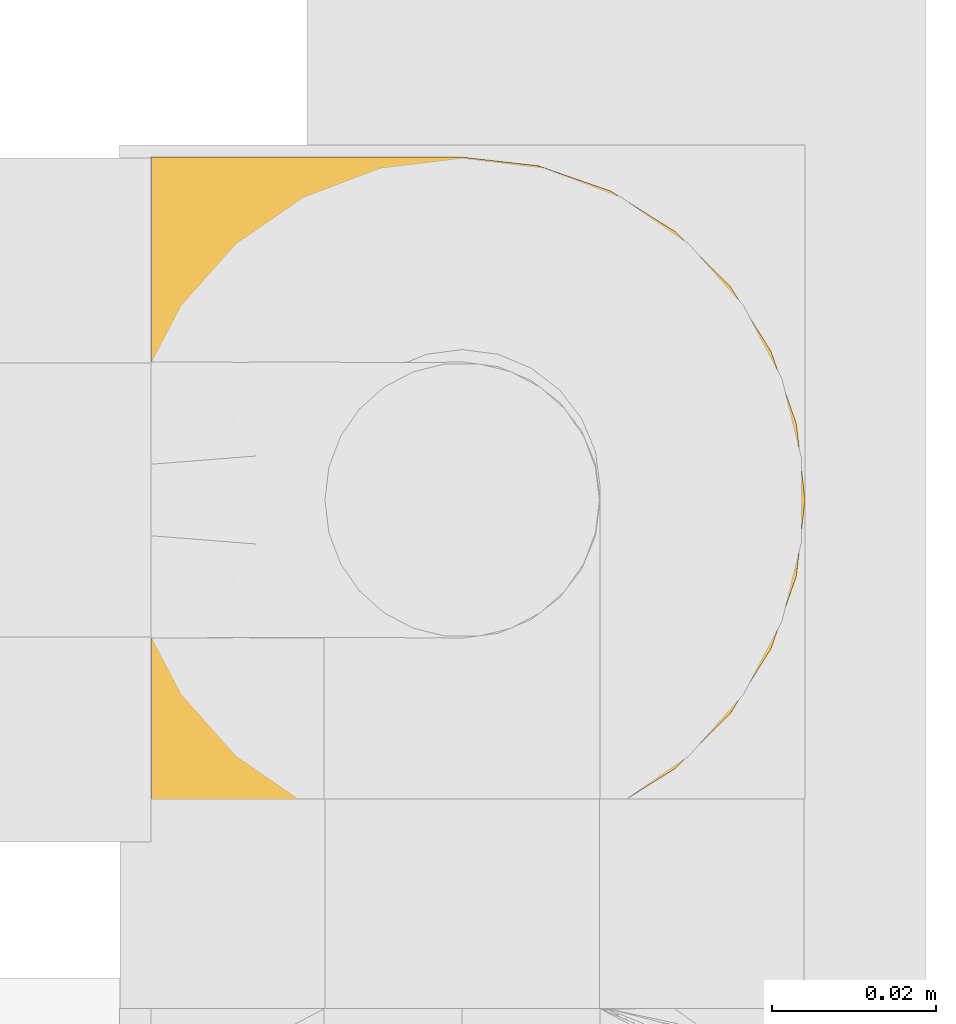
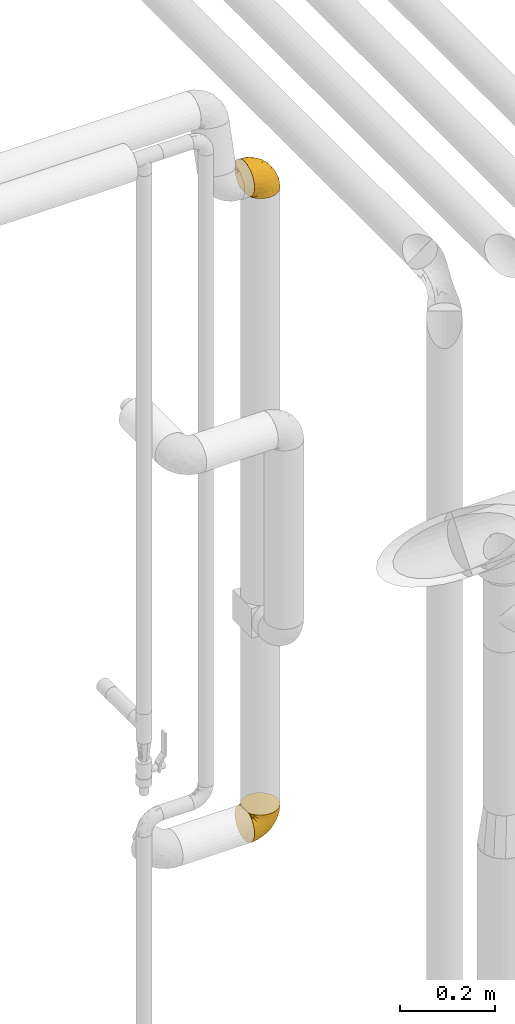
# One storey, part 355 of 827: 2 coverings.
"""IFC2X3 building model written with IfcOpenShell, lengths in millimetres."""

from ifc_helpers import new_model, entity, si_unit, converted_unit, derived_unit, direction, frame, origin, place, context, subcontext, project, spatial, faceted_brep, element, save


model = new_model("IFC2X3")

# Units and contexts
model_context = context("Model", 3, precision=0.01, world=origin(), true_north=direction((6.12303176911189e-17, 1.0)))
body_context = subcontext(model_context, "Body", "Model", "MODEL_VIEW")
ifc_project = project(units=[si_unit("LENGTHUNIT", "METRE", prefix="MILLI"), si_unit("AREAUNIT", "SQUARE_METRE"), si_unit("VOLUMEUNIT", "CUBIC_METRE"), converted_unit("PLANEANGLEUNIT", "DEGREE", entity("IfcRatioMeasure", 0.0174532925199433), si_unit("PLANEANGLEUNIT", "RADIAN"), dimensions=[0, 0, 0, 0, 0, 0, 0]), si_unit("MASSUNIT", "GRAM", prefix="KILO"), derived_unit("MASSDENSITYUNIT", [(si_unit("MASSUNIT", "GRAM", prefix="KILO"), 1), (si_unit("LENGTHUNIT", "METRE"), -3)]), derived_unit("MOMENTOFINERTIAUNIT", [(si_unit("LENGTHUNIT", "METRE"), 4)]), si_unit("TIMEUNIT", "SECOND"), si_unit("FREQUENCYUNIT", "HERTZ"), si_unit("THERMODYNAMICTEMPERATUREUNIT", "DEGREE_CELSIUS"), derived_unit("THERMALTRANSMITTANCEUNIT", [(si_unit("MASSUNIT", "GRAM", prefix="KILO"), 1), (si_unit("THERMODYNAMICTEMPERATUREUNIT", "KELVIN"), -1), (si_unit("TIMEUNIT", "SECOND"), -3)]), derived_unit("VOLUMETRICFLOWRATEUNIT", [(si_unit("LENGTHUNIT", "METRE"), 3), (si_unit("TIMEUNIT", "SECOND"), -1)]), derived_unit("MASSFLOWRATEUNIT", [(si_unit("MASSUNIT", "GRAM", prefix="KILO"), 1), (si_unit("TIMEUNIT", "SECOND"), -1)]), derived_unit("ROTATIONALFREQUENCYUNIT", [(si_unit("TIMEUNIT", "SECOND"), -1)]), si_unit("ELECTRICCURRENTUNIT", "AMPERE"), si_unit("ELECTRICVOLTAGEUNIT", "VOLT"), si_unit("POWERUNIT", "WATT"), si_unit("FORCEUNIT", "NEWTON", prefix="KILO"), si_unit("ILLUMINANCEUNIT", "LUX"), si_unit("LUMINOUSFLUXUNIT", "LUMEN"), si_unit("LUMINOUSINTENSITYUNIT", "CANDELA"), derived_unit("USERDEFINED", [(si_unit("MASSUNIT", "GRAM", prefix="KILO"), -1), (si_unit("LENGTHUNIT", "METRE"), -2), (si_unit("TIMEUNIT", "SECOND"), 3), (si_unit("LUMINOUSFLUXUNIT", "LUMEN"), 1)]), derived_unit("LINEARVELOCITYUNIT", [(si_unit("LENGTHUNIT", "METRE"), 1), (si_unit("TIMEUNIT", "SECOND"), -1)]), si_unit("PRESSUREUNIT", "PASCAL"), derived_unit("USERDEFINED", [(si_unit("LENGTHUNIT", "METRE"), -2), (si_unit("MASSUNIT", "GRAM", prefix="KILO"), 1), (si_unit("TIMEUNIT", "SECOND"), -2)]), derived_unit("LINEARFORCEUNIT", [(si_unit("MASSUNIT", "GRAM", prefix="KILO"), 1), (si_unit("LENGTHUNIT", "METRE"), 1), (si_unit("TIMEUNIT", "SECOND"), -2), (si_unit("LENGTHUNIT", "METRE"), -1)]), derived_unit("PLANARFORCEUNIT", [(si_unit("MASSUNIT", "GRAM", prefix="KILO"), 1), (si_unit("LENGTHUNIT", "METRE"), 1), (si_unit("TIMEUNIT", "SECOND"), -2), (si_unit("LENGTHUNIT", "METRE"), -2)])], contexts=[model_context])

# Site, building, storey
site_placement = place(None, origin())
site = spatial("IfcSite", under=ifc_project, at=site_placement, CompositionType="ELEMENT")
building_placement = place(site_placement, origin())
building = spatial("IfcBuilding", under=site, at=building_placement, CompositionType="ELEMENT")
storey_placement = place(building_placement, frame((0.0, 0.0, 28200.0)))
storey = spatial("IfcBuildingStorey", under=building, at=storey_placement, Name="08", CompositionType="ELEMENT", Elevation=28200.0)

# Coverings
covering_1_placement = place(storey_placement, frame((43536.62, 15237.88, 1117.26)))
element("IfcCovering", 1, at=covering_1_placement, inside=storey, Name=":ADSK_", ObjectType=":ADSK_", PredefinedType="INSULATION", context=body_context, shape_type="Brep", body=[
    faceted_brep([(57.76, 5.74, 81.45), (65.69, 10.73, 81.45), (72.32, 17.36, 81.45), (77.3, 25.29, 81.45), (80.4, 34.14, 81.45), (81.45, 43.45, 81.45), (80.39, 52.76, 81.45), (77.3, 61.61, 81.45), (72.31, 69.54, 81.45), (65.68, 76.17, 81.45), (57.75, 81.15, 81.45), (48.9, 84.25, 81.45), (39.6, 85.3, 81.45), (30.22, 84.23, 81.45), (21.33, 81.1, 81.45), (13.37, 76.06, 81.45), (6.73, 69.36, 81.45), (1.77, 61.36, 81.45), (1.77, 60.44, 81.45), (1.77, 59.52, 81.45), (1.77, 58.72, 81.45), (1.77, 57.4, 81.45), (1.77, 56.08, 81.45), (1.77, 54.76, 81.45), (1.77, 53.44, 81.45), (1.77, 52.12, 81.45), (1.77, 50.8, 81.45), (1.77, 49.47, 81.45), (1.77, 48.15, 81.45), (1.77, 46.83, 81.45), (1.77, 45.51, 81.45), (1.77, 44.19, 81.45), (1.77, 42.87, 81.45), (1.77, 41.55, 81.45), (1.77, 40.23, 81.45), (1.77, 39.31, 81.45), (1.77, 38.39, 81.45), (1.77, 37.48, 81.45), (1.77, 36.56, 81.45), (1.77, 35.64, 81.45), (1.77, 34.72, 81.45), (1.77, 33.8, 81.45), (1.77, 32.88, 81.45), (1.77, 31.96, 81.45), (1.77, 31.05, 81.45), (1.77, 30.13, 81.45), (1.77, 29.21, 81.45), (1.77, 28.29, 81.45), (1.77, 27.37, 81.45), (1.77, 26.45, 81.45), (1.77, 25.53, 81.45), (6.74, 17.52, 81.45), (13.38, 10.82, 81.45), (21.35, 5.78, 81.45), (30.24, 2.65, 81.45), (39.6, 1.6, 81.45), (48.91, 2.65, 81.45), (1.6, 69.37, 76.3), (1.6, 76.06, 69.67), (1.6, 81.1, 61.7), (1.6, 84.23, 52.81), (1.6, 85.3, 43.45), (1.6, 83.87, 32.61), (1.6, 79.69, 22.52), (1.6, 73.04, 13.85), (1.6, 64.37, 7.2), (1.6, 54.28, 3.02), (1.6, 43.45, 1.6), (1.6, 32.61, 3.02), (1.6, 22.52, 7.2), (1.6, 13.85, 13.85), (1.6, 7.2, 22.52), (1.6, 3.02, 32.61), (1.6, 1.6, 43.45), (1.6, 2.66, 52.81), (1.6, 5.79, 61.7), (1.6, 10.83, 69.67), (1.6, 17.52, 76.3), (1.6, 25.53, 81.27), (1.6, 26.45, 81.27), (1.6, 27.77, 81.27), (1.6, 28.89, 81.27), (1.6, 30.01, 81.27), (1.6, 31.13, 81.27), (1.6, 32.25, 81.27), (1.6, 33.37, 81.27), (1.6, 34.49, 81.27), (1.6, 35.61, 81.27), (1.6, 36.73, 81.27), (1.6, 37.85, 81.27), (1.6, 38.97, 81.27), (1.6, 40.09, 81.27), (1.6, 41.21, 81.27), (1.6, 42.33, 81.27), (1.6, 43.45, 81.27), (1.6, 44.77, 81.27), (1.6, 46.09, 81.27), (1.6, 47.41, 81.27), (1.6, 48.73, 81.27), (1.6, 50.05, 81.27), (1.6, 51.37, 81.27), (1.6, 52.69, 81.27), (1.6, 54.01, 81.27), (1.6, 54.93, 81.27), (1.6, 55.85, 81.27), (1.6, 56.76, 81.27), (1.6, 57.68, 81.27), (1.6, 58.6, 81.27), (1.6, 59.52, 81.27), (1.6, 60.44, 81.27), (1.6, 61.36, 81.27), (1.71, 32.81, 81.31), (1.73, 31.73, 81.33), (1.71, 50.71, 81.31), (1.72, 51.76, 81.32), (1.71, 42.89, 81.31), (1.72, 41.81, 81.32), (1.72, 25.53, 81.32), (1.72, 26.91, 81.32), (1.72, 40.71, 81.32), (1.72, 60.15, 81.32), (1.72, 39.53, 81.32), (1.72, 57.22, 81.32), (1.7, 58.17, 81.3), (1.72, 47.12, 81.32), (1.73, 33.93, 81.33), (1.72, 35.05, 81.31), (1.73, 46.09, 81.33), (1.73, 45.02, 81.32), (1.72, 43.95, 81.32), (1.72, 59.12, 81.32), (1.71, 38.49, 81.31), (1.72, 49.68, 81.32), (1.71, 53.35, 81.31), (1.72, 54.4, 81.32), (1.72, 56.2, 81.32), (1.72, 36.2, 81.32), (1.73, 37.29, 81.33), (1.72, 30.57, 81.32), (1.71, 29.45, 81.31), (1.73, 28.01, 81.33), (1.72, 61.36, 81.32), (1.74, 25.53, 81.36), (1.75, 25.53, 81.4), (1.75, 61.36, 81.4), (1.74, 61.36, 81.36), (1.64, 25.53, 81.29), (1.68, 25.53, 81.3), (1.68, 61.36, 81.3), (1.64, 61.36, 81.29), (1.74, 55.3, 81.35), (1.71, 48.18, 81.31), (8.98, 82.92, 58.5), (37.05, 85.3, 71.95), (24.69, 82.92, 74.57), (15.28, 78.8, 73.93), (16.86, 78.8, 78.18), (6.58, 70.46, 78.04), (5.71, 71.16, 76.23), (11.1, 85.3, 45.99), (10.79, 76.1, 74.01), (4.13, 72.9, 73.57), (6.62, 78.81, 66.66), (9.52, 72.89, 79.09), (6.14, 74.06, 73.14), (17.79, 83.71, 60.34), (20.6, 85.3, 48.54), (8.73, 85.3, 45.36), (23.66, 83.61, 67.22), (34.5, 85.3, 62.45), (15.32, 80.61, 68.67), (27.55, 85.3, 55.49), (3.31, 67.83, 77.84), (9.81, 78.81, 68.16), (37.68, 85.3, 74.31), (67.23, 54.78, 38.78), (76.64, 57.27, 62.1), (75.37, 43.45, 50.89), (14.58, 84.45, 36.91), (23.71, 84.39, 40.37), (34.34, 77.16, 27.86), (29.1, 68.92, 15.77), (18.02, 76.65, 20.13), (22.27, 82.11, 31.54), (10.97, 82.11, 28.25), (56.79, 78.88, 57.26), (60.76, 78.88, 69.99), (67.04, 73.04, 64.58), (36.11, 84.47, 50.64), (68.85, 65.72, 51.97), (24.58, 51.16, 5.72), (21.54, 59.46, 7.42), (78.4, 43.45, 66.14), (14.11, 68.92, 11.35), (53.42, 51.18, 21.64), (58.19, 57.42, 28.57), (44.49, 83.48, 55.38), (51.77, 82.95, 68.51), (73.69, 65.72, 67.48), (45.89, 78.97, 40.78), (35.97, 82.64, 41.53), (56.55, 75.14, 46.11), (60.03, 68.58, 40.32), (63.64, 61.95, 38.36), (34.98, 58.11, 11.84), (40.58, 51.07, 12.56), (32.15, 43.45, 7.67), (47.26, 58.51, 19.39), (58.06, 43.45, 24.98), (66.71, 43.45, 37.94), (16.9, 43.45, 4.64), (52.08, 65.68, 28.09), (41.21, 70.41, 23.73), (49.76, 73.04, 34.03), (45.11, 43.45, 16.33), (15.65, 4.78, 29.29), (24.57, 35.48, 5.77), (50.54, 29.45, 21.44), (67.25, 32.11, 38.8), (67.06, 13.86, 64.58), (73.7, 21.19, 67.49), (26.13, 10.24, 22.9), (19.54, 17.97, 12.54), (38.96, 18.88, 20.04), (56.8, 8.01, 57.26), (60.77, 8.01, 69.99), (51.78, 3.95, 68.51), (59.09, 22.45, 34.54), (19.25, 2.4, 38.81), (20.6, 1.6, 48.54), (11.1, 1.6, 45.99), (37.68, 1.6, 74.31), (15.21, 29.05, 5.36), (12.76, 10.24, 18.96), (40.93, 35.7, 12.79), (76.65, 29.63, 62.11), (39.5, 8.75, 33.14), (25.01, 4.54, 33.44), (68.86, 21.19, 51.98), (26.7, 2.28, 43.42), (34.95, 2.53, 48.62), (34.5, 1.6, 62.45), (27.55, 1.6, 55.49), (61.27, 13.86, 49.68), (44.5, 3.41, 55.37), (37.05, 1.6, 71.95), (10.25, 2.35, 36.37), (49.78, 13.86, 34.04), (47.51, 7.35, 44.1), (29.38, 27.43, 9.99), (40.01, 13.39, 26.41), (33.36, 4.32, 39.19), (8.98, 3.97, 58.5), (23.67, 3.27, 67.22), (24.71, 3.97, 74.57), (15.29, 8.08, 73.92), (4.13, 13.99, 73.57), (6.14, 12.83, 73.14), (4.96, 8.08, 66.19), (9.81, 8.08, 68.16), (3.31, 19.06, 77.84), (5.7, 15.74, 76.23), (9.53, 13.98, 79.08), (6.59, 16.42, 78.04), (16.63, 8.08, 77.18), (15.34, 6.27, 68.66), (10.8, 10.78, 74.0), (17.79, 3.18, 60.34)], [[[0, 1, 2, 3, 4, 5, 6, 7, 8, 9, 10, 11, 12, 13, 14, 15, 16, 17, 18, 19, 20, 21, 22, 23, 24, 25, 26, 27, 28, 29, 30, 31, 32, 33, 34, 35, 36, 37, 38, 39, 40, 41, 42, 43, 44, 45, 46, 47, 48, 49, 50, 51, 52, 53, 54, 55, 56]], [[57, 58, 59, 60, 61, 62, 63, 64, 65, 66, 67, 68, 69, 70, 71, 72, 73, 74, 75, 76, 77, 78, 79, 80, 81, 82, 83, 84, 85, 86, 87, 88, 89, 90, 91, 92, 93, 94, 95, 96, 97, 98, 99, 100, 101, 102, 103, 104, 105, 106, 107, 108, 109, 110]], [[111, 84, 112]], [[113, 26, 114]], [[114, 101, 100]], [[115, 93, 116]], [[79, 117, 118]], [[33, 116, 119]], [[117, 49, 118]], [[19, 18, 120]], [[119, 121, 34]], [[122, 21, 123]], [[97, 96, 124]], [[86, 125, 126]], [[116, 92, 119]], [[127, 96, 128]], [[32, 129, 115]], [[19, 120, 130]], [[121, 90, 131]], [[94, 115, 129]], [[115, 116, 32]], [[118, 49, 48]], [[113, 99, 132]], [[133, 114, 25]], [[24, 134, 133]], [[135, 22, 122]], [[136, 137, 88]], [[84, 83, 112]], [[138, 82, 139]], [[130, 20, 19]], [[118, 48, 140]], [[81, 140, 139]], [[123, 21, 20]], [[141, 120, 18]], [[139, 82, 81]], [[130, 107, 123]], [[49, 117, 142, 143, 50]], [[18, 17, 144, 145, 141]], [[79, 78, 146, 147, 117]], [[109, 141, 148, 149, 110]], [[102, 133, 134]], [[105, 135, 122]], [[118, 80, 79]], [[80, 118, 140]], [[120, 109, 108]], [[47, 46, 140, 48]], [[81, 80, 140]], [[44, 112, 138]], [[93, 115, 94]], [[46, 139, 140]], [[46, 45, 139]], [[139, 45, 138]], [[138, 112, 83]], [[85, 84, 111]], [[112, 43, 111]], [[83, 82, 138]], [[106, 122, 123]], [[105, 122, 106]], [[21, 122, 22]], [[124, 29, 28]], [[33, 32, 116]], [[128, 129, 31]], [[32, 31, 129]], [[34, 33, 119]], [[116, 93, 92]], [[129, 95, 94]], [[95, 129, 128]], [[41, 40, 125, 42]], [[119, 91, 121]], [[36, 35, 131, 37]], [[137, 131, 89]], [[121, 131, 35]], [[90, 121, 91]], [[119, 92, 91]], [[136, 126, 39]], [[125, 86, 85]], [[42, 125, 111]], [[85, 111, 125]], [[150, 23, 22]], [[130, 108, 107]], [[130, 123, 20]], [[107, 106, 123]], [[137, 37, 131]], [[136, 38, 137]], [[89, 88, 137]], [[131, 90, 89]], [[124, 151, 97]], [[40, 39, 126]], [[87, 126, 136]], [[86, 126, 87]], [[136, 88, 87]], [[40, 126, 125]], [[39, 38, 136]], [[95, 128, 96]], [[30, 128, 31]], [[29, 124, 127]], [[127, 128, 30]], [[151, 124, 28]], [[127, 30, 29]], [[127, 124, 96]], [[151, 98, 97]], [[45, 44, 138]], [[26, 113, 132]], [[113, 100, 99]], [[132, 151, 27]], [[27, 26, 132]], [[26, 25, 114]], [[100, 113, 114]], [[101, 133, 102]], [[133, 101, 114]], [[28, 27, 151]], [[132, 99, 98]], [[23, 134, 24]], [[25, 24, 133]], [[134, 23, 150]], [[135, 104, 150]], [[150, 104, 103]], [[103, 102, 134]], [[130, 120, 108]], [[109, 120, 141]], [[42, 111, 43]], [[112, 44, 43]], [[104, 135, 105]], [[134, 150, 103]], [[135, 150, 22]], [[35, 34, 121]], [[137, 38, 37]], [[98, 151, 132]], [[59, 152, 60]], [[13, 153, 154]], [[155, 156, 154]], [[157, 158, 141]], [[159, 60, 152]], [[160, 157, 155]], [[161, 162, 58]], [[58, 162, 59]], [[144, 16, 163]], [[58, 57, 161]], [[162, 161, 164]], [[157, 163, 155]], [[163, 16, 15]], [[57, 149, 161]], [[152, 165, 166]], [[157, 144, 163]], [[60, 159, 167, 61]], [[156, 14, 154]], [[163, 156, 155]], [[155, 154, 168]], [[168, 154, 169]], [[155, 170, 160]], [[57, 110, 149]], [[144, 17, 16]], [[156, 15, 14]], [[171, 165, 168]], [[158, 164, 172]], [[14, 13, 154]], [[157, 141, 145, 144]], [[173, 164, 158]], [[173, 160, 170]], [[171, 166, 165]], [[168, 165, 170]], [[168, 169, 171]], [[152, 173, 165]], [[170, 155, 168]], [[165, 173, 170]], [[160, 173, 158]], [[172, 149, 148]], [[148, 141, 158]], [[158, 157, 160]], [[152, 166, 159]], [[173, 152, 162]], [[59, 162, 152]], [[13, 12, 174, 153]], [[153, 169, 154]], [[15, 156, 163]], [[162, 164, 173]], [[172, 164, 161]], [[149, 172, 161]], [[158, 172, 148]], [[175, 176, 177]], [[178, 166, 179]], [[180, 181, 182]], [[183, 184, 178]], [[185, 186, 187]], [[171, 188, 179]], [[174, 12, 11]], [[189, 176, 175]], [[190, 66, 191]], [[176, 6, 192]], [[193, 65, 64]], [[63, 184, 182]], [[63, 182, 64]], [[65, 193, 191]], [[184, 63, 62]], [[175, 194, 195]], [[196, 169, 197]], [[174, 11, 197]], [[8, 7, 198]], [[187, 9, 8]], [[197, 169, 153, 174]], [[197, 11, 10]], [[186, 197, 10]], [[199, 180, 200]], [[197, 185, 196]], [[201, 189, 202]], [[201, 187, 189]], [[195, 203, 175]], [[191, 204, 190]], [[176, 7, 6]], [[177, 176, 192]], [[189, 198, 176]], [[65, 191, 66]], [[198, 187, 8]], [[205, 206, 190]], [[9, 186, 10]], [[181, 207, 204]], [[208, 175, 177, 209]], [[66, 190, 210]], [[211, 212, 213]], [[190, 204, 205]], [[180, 182, 183]], [[193, 182, 181]], [[62, 61, 167]], [[196, 185, 199]], [[196, 200, 188]], [[6, 5, 192]], [[176, 198, 7]], [[187, 198, 189]], [[187, 186, 9]], [[197, 186, 185]], [[200, 180, 183]], [[180, 213, 212]], [[179, 183, 178]], [[185, 201, 199]], [[210, 190, 206]], [[210, 67, 66]], [[205, 204, 207]], [[194, 205, 207]], [[194, 214, 205]], [[195, 194, 207]], [[208, 194, 175]], [[207, 211, 195]], [[202, 203, 211]], [[212, 207, 181]], [[202, 211, 213]], [[201, 202, 213]], [[189, 175, 203]], [[199, 201, 213]], [[187, 201, 185]], [[180, 199, 213]], [[196, 199, 200]], [[211, 203, 195]], [[189, 203, 202]], [[207, 212, 211]], [[180, 212, 181]], [[214, 194, 208]], [[214, 206, 205]], [[196, 188, 169]], [[181, 204, 191]], [[182, 193, 64]], [[191, 193, 181]], [[178, 62, 167]], [[182, 184, 183]], [[62, 178, 184]], [[178, 167, 159, 166]], [[171, 179, 166]], [[200, 183, 179]], [[179, 188, 200]], [[169, 188, 171]], [[71, 215, 72]], [[206, 216, 210]], [[217, 208, 218]], [[216, 68, 210]], [[219, 220, 2]], [[221, 222, 223]], [[224, 225, 226]], [[227, 223, 217]], [[228, 229, 230]], [[56, 231, 226]], [[232, 222, 69]], [[56, 55, 231]], [[70, 233, 71]], [[71, 233, 215]], [[0, 56, 226]], [[208, 217, 234]], [[218, 177, 235]], [[221, 236, 237]], [[238, 220, 219]], [[1, 219, 2]], [[68, 216, 232]], [[235, 3, 220]], [[235, 192, 4]], [[1, 0, 225]], [[228, 239, 229]], [[240, 241, 242]], [[243, 238, 219]], [[224, 226, 244]], [[226, 241, 244]], [[3, 235, 4]], [[69, 222, 70]], [[225, 219, 1]], [[218, 235, 238]], [[243, 219, 224]], [[218, 227, 217]], [[3, 2, 220]], [[218, 208, 209, 177]], [[226, 231, 245, 241]], [[215, 228, 246]], [[247, 248, 236]], [[248, 224, 244]], [[223, 222, 249]], [[233, 222, 221]], [[242, 239, 240]], [[248, 247, 243]], [[217, 223, 249]], [[250, 247, 236]], [[216, 234, 249]], [[218, 238, 227]], [[192, 235, 177]], [[192, 5, 4]], [[72, 246, 73]], [[235, 220, 238]], [[226, 225, 0]], [[219, 225, 224]], [[240, 248, 244]], [[239, 242, 229]], [[236, 248, 251]], [[68, 67, 210]], [[234, 216, 206]], [[216, 249, 232]], [[234, 206, 214, 208]], [[249, 234, 217]], [[222, 232, 249]], [[69, 68, 232]], [[246, 228, 230]], [[237, 228, 215]], [[243, 227, 238]], [[223, 227, 247]], [[73, 246, 230]], [[215, 246, 72]], [[248, 243, 224]], [[227, 243, 247]], [[237, 236, 251]], [[250, 221, 223]], [[222, 233, 70]], [[215, 233, 221]], [[221, 237, 215]], [[239, 237, 251]], [[237, 239, 228]], [[239, 251, 240]], [[248, 240, 251]], [[241, 240, 244]], [[221, 250, 236]], [[223, 247, 250]], [[74, 230, 252]], [[253, 254, 255]], [[146, 77, 256]], [[257, 258, 259]], [[260, 256, 257]], [[260, 261, 147]], [[75, 74, 252]], [[51, 143, 262]], [[263, 143, 142, 117]], [[256, 77, 76]], [[252, 258, 75]], [[253, 241, 254]], [[254, 245, 54]], [[258, 256, 76]], [[53, 52, 264]], [[255, 265, 253]], [[254, 264, 255]], [[255, 264, 262]], [[75, 258, 76]], [[265, 255, 266]], [[255, 262, 263]], [[51, 50, 143]], [[54, 245, 231, 55]], [[51, 262, 52]], [[253, 267, 242]], [[254, 54, 53]], [[266, 259, 265]], [[146, 78, 77]], [[263, 117, 261]], [[146, 256, 260]], [[257, 259, 261]], [[267, 253, 265]], [[229, 267, 252]], [[242, 267, 229]], [[242, 241, 253]], [[252, 267, 259]], [[255, 263, 266]], [[259, 267, 265]], [[261, 117, 147]], [[263, 261, 266]], [[259, 266, 261]], [[230, 74, 73]], [[230, 229, 252]], [[259, 258, 252]], [[254, 241, 245]], [[53, 264, 254]], [[52, 262, 264]], [[143, 263, 262]], [[258, 257, 256]], [[261, 260, 257]], [[146, 260, 147]]]),
])
covering_2_placement = place(storey_placement, frame((43536.62, 15237.88, 2782.61)))
element("IfcCovering", 2, at=covering_2_placement, inside=storey, Name=":ADSK_", ObjectType=":ADSK_", PredefinedType="INSULATION", context=body_context, shape_type="Brep", body=[
    faceted_brep([(57.76, 81.15, 1.6), (65.69, 76.16, 1.6), (72.32, 69.53, 1.6), (77.3, 61.6, 1.6), (80.4, 52.75, 1.6), (81.45, 43.45, 1.6), (80.39, 34.13, 1.6), (77.3, 25.28, 1.6), (72.31, 17.35, 1.6), (65.68, 10.72, 1.6), (57.75, 5.74, 1.6), (48.9, 2.64, 1.6), (39.6, 1.6, 1.6), (30.22, 2.66, 1.6), (21.33, 5.79, 1.6), (13.37, 10.83, 1.6), (6.73, 17.53, 1.6), (1.77, 25.53, 1.6), (1.77, 26.45, 1.6), (1.77, 27.37, 1.6), (1.77, 28.17, 1.6), (1.77, 29.49, 1.6), (1.77, 30.81, 1.6), (1.77, 32.13, 1.6), (1.77, 33.45, 1.6), (1.77, 34.78, 1.6), (1.77, 36.1, 1.6), (1.77, 37.42, 1.6), (1.77, 38.74, 1.6), (1.77, 40.06, 1.6), (1.77, 41.38, 1.6), (1.77, 42.7, 1.6), (1.77, 44.02, 1.6), (1.77, 45.34, 1.6), (1.77, 46.66, 1.6), (1.77, 47.58, 1.6), (1.77, 48.5, 1.6), (1.77, 49.41, 1.6), (1.77, 50.33, 1.6), (1.77, 51.25, 1.6), (1.77, 52.17, 1.6), (1.77, 53.09, 1.6), (1.77, 54.01, 1.6), (1.77, 54.93, 1.6), (1.77, 55.85, 1.6), (1.77, 56.76, 1.6), (1.77, 57.68, 1.6), (1.77, 58.6, 1.6), (1.77, 59.52, 1.6), (1.77, 60.44, 1.6), (1.77, 61.36, 1.6), (6.74, 69.37, 1.6), (13.38, 76.07, 1.6), (21.35, 81.11, 1.6), (30.24, 84.24, 1.6), (39.6, 85.3, 1.6), (48.91, 84.24, 1.6), (1.6, 17.52, 6.74), (1.6, 10.83, 13.37), (1.6, 5.79, 21.34), (1.6, 2.66, 30.23), (1.6, 1.6, 39.6), (1.6, 3.02, 50.43), (1.6, 7.2, 60.52), (1.6, 13.85, 69.19), (1.6, 22.52, 75.84), (1.6, 32.61, 80.02), (1.6, 43.45, 81.45), (1.6, 54.28, 80.02), (1.6, 64.37, 75.84), (1.6, 73.04, 69.19), (1.6, 79.69, 60.52), (1.6, 83.87, 50.43), (1.6, 85.3, 39.6), (1.6, 84.23, 30.23), (1.6, 81.1, 21.34), (1.6, 76.06, 13.37), (1.6, 69.37, 6.74), (1.6, 61.36, 1.77), (1.6, 60.44, 1.77), (1.6, 59.12, 1.77), (1.6, 58.0, 1.77), (1.6, 56.88, 1.77), (1.6, 55.76, 1.77), (1.6, 54.64, 1.77), (1.6, 53.52, 1.77), (1.6, 52.4, 1.77), (1.6, 51.28, 1.77), (1.6, 50.16, 1.77), (1.6, 49.04, 1.77), (1.6, 47.92, 1.77), (1.6, 46.8, 1.77), (1.6, 45.68, 1.77), (1.6, 44.56, 1.77), (1.6, 43.45, 1.77), (1.6, 42.12, 1.77), (1.6, 40.8, 1.77), (1.6, 39.48, 1.77), (1.6, 38.16, 1.77), (1.6, 36.84, 1.77), (1.6, 35.52, 1.77), (1.6, 34.2, 1.77), (1.6, 32.88, 1.77), (1.6, 31.96, 1.77), (1.6, 31.05, 1.77), (1.6, 30.13, 1.77), (1.6, 29.21, 1.77), (1.6, 28.29, 1.77), (1.6, 27.37, 1.77), (1.6, 26.45, 1.77), (1.6, 25.53, 1.77), (1.71, 54.08, 1.73), (1.73, 55.16, 1.72), (1.71, 36.18, 1.73), (1.72, 35.13, 1.72), (1.71, 44.01, 1.73), (1.72, 45.08, 1.73), (1.72, 61.36, 1.72), (1.72, 59.98, 1.72), (1.72, 46.18, 1.72), (1.72, 26.74, 1.72), (1.72, 47.36, 1.72), (1.72, 29.67, 1.73), (1.7, 28.72, 1.74), (1.72, 39.77, 1.72), (1.73, 52.96, 1.71), (1.72, 51.84, 1.73), (1.73, 40.8, 1.71), (1.73, 41.87, 1.72), (1.72, 42.94, 1.73), (1.72, 27.77, 1.72), (1.71, 48.4, 1.73), (1.72, 37.21, 1.72), (1.71, 33.54, 1.73), (1.72, 32.49, 1.72), (1.72, 30.69, 1.72), (1.72, 50.69, 1.72), (1.73, 49.6, 1.71), (1.72, 56.32, 1.72), (1.71, 57.44, 1.73), (1.73, 58.88, 1.71), (1.72, 25.53, 1.72), (1.74, 61.36, 1.68), (1.75, 61.36, 1.64), (1.75, 25.53, 1.64), (1.74, 25.53, 1.68), (1.64, 61.36, 1.75), (1.68, 61.36, 1.74), (1.68, 25.53, 1.74), (1.64, 25.53, 1.75), (1.74, 31.59, 1.7), (1.71, 38.71, 1.73), (8.98, 3.97, 24.54), (37.05, 1.6, 11.1), (24.69, 3.97, 8.47), (15.28, 8.09, 9.11), (16.86, 8.09, 4.86), (6.58, 16.43, 5.0), (5.71, 15.73, 6.81), (11.1, 1.6, 37.05), (10.79, 10.79, 9.03), (4.13, 13.99, 9.47), (6.62, 8.08, 16.39), (9.52, 14.0, 3.95), (6.14, 12.83, 9.9), (17.79, 3.18, 22.7), (20.6, 1.6, 34.5), (8.73, 1.6, 37.68), (23.66, 3.28, 15.82), (34.5, 1.6, 20.6), (15.32, 6.28, 14.37), (27.55, 1.6, 27.55), (3.31, 19.06, 5.2), (9.81, 8.08, 14.88), (37.68, 1.6, 8.73), (67.23, 32.11, 44.27), (76.64, 29.62, 20.94), (75.37, 43.45, 32.15), (14.58, 2.45, 46.13), (23.71, 2.5, 42.67), (34.34, 9.73, 55.18), (29.1, 17.97, 67.27), (18.02, 10.24, 62.91), (22.27, 4.78, 51.5), (10.97, 4.78, 54.79), (56.79, 8.01, 25.78), (60.76, 8.01, 13.05), (67.04, 13.85, 18.46), (36.11, 2.42, 32.4), (68.85, 21.17, 31.07), (24.58, 35.73, 77.32), (21.54, 27.43, 75.62), (78.4, 43.45, 16.9), (14.11, 17.97, 71.69), (53.42, 35.71, 61.4), (58.19, 29.47, 54.47), (44.49, 3.41, 27.66), (51.77, 3.94, 14.53), (73.69, 21.17, 15.56), (45.89, 7.92, 42.26), (35.97, 4.25, 41.51), (56.55, 11.75, 36.93), (60.03, 18.31, 42.72), (63.64, 24.94, 44.68), (34.98, 28.78, 71.2), (40.58, 35.82, 70.48), (32.15, 43.45, 75.37), (47.26, 28.38, 63.65), (58.06, 43.45, 58.06), (66.71, 43.45, 45.11), (16.9, 43.45, 78.4), (52.08, 21.21, 54.95), (41.21, 16.48, 59.31), (49.76, 13.85, 49.01), (45.11, 43.45, 66.71), (15.65, 82.11, 53.75), (24.57, 51.41, 77.27), (50.54, 57.45, 61.6), (67.25, 54.78, 44.24), (67.06, 73.03, 18.46), (73.7, 65.7, 15.55), (26.13, 76.65, 60.14), (19.54, 68.92, 70.5), (38.96, 68.01, 63.0), (56.8, 78.88, 25.78), (60.77, 78.88, 13.05), (51.78, 82.94, 14.53), (59.09, 64.44, 48.5), (19.25, 84.49, 44.23), (20.6, 85.3, 34.5), (11.1, 85.3, 37.05), (37.68, 85.3, 8.73), (15.21, 57.84, 77.68), (12.76, 76.65, 64.08), (40.93, 51.19, 70.25), (76.65, 57.26, 20.93), (39.5, 78.14, 49.9), (25.01, 82.35, 49.6), (68.86, 65.7, 31.06), (26.7, 84.61, 39.62), (34.95, 84.36, 34.42), (34.5, 85.3, 20.6), (27.55, 85.3, 27.55), (61.27, 73.03, 33.36), (44.5, 83.48, 27.68), (37.05, 85.3, 11.1), (10.25, 84.54, 46.67), (49.78, 73.03, 49.0), (47.51, 79.54, 38.94), (29.38, 59.46, 73.05), (40.01, 73.5, 56.63), (33.36, 82.57, 43.85), (8.98, 82.92, 24.54), (23.67, 83.62, 15.82), (24.71, 82.92, 8.47), (15.29, 78.81, 9.12), (4.13, 72.9, 9.47), (6.14, 74.06, 9.91), (4.96, 78.81, 16.85), (9.81, 78.81, 14.88), (3.31, 67.83, 5.2), (5.7, 71.15, 6.81), (9.53, 72.91, 3.96), (6.59, 70.47, 5.0), (16.63, 78.81, 5.86), (15.34, 80.62, 14.38), (10.8, 76.11, 9.04), (17.79, 83.71, 22.7)], [[[0, 1, 2, 3, 4, 5, 6, 7, 8, 9, 10, 11, 12, 13, 14, 15, 16, 17, 18, 19, 20, 21, 22, 23, 24, 25, 26, 27, 28, 29, 30, 31, 32, 33, 34, 35, 36, 37, 38, 39, 40, 41, 42, 43, 44, 45, 46, 47, 48, 49, 50, 51, 52, 53, 54, 55, 56]], [[57, 58, 59, 60, 61, 62, 63, 64, 65, 66, 67, 68, 69, 70, 71, 72, 73, 74, 75, 76, 77, 78, 79, 80, 81, 82, 83, 84, 85, 86, 87, 88, 89, 90, 91, 92, 93, 94, 95, 96, 97, 98, 99, 100, 101, 102, 103, 104, 105, 106, 107, 108, 109, 110]], [[111, 84, 112]], [[113, 26, 114]], [[114, 101, 100]], [[115, 93, 116]], [[79, 117, 118]], [[33, 116, 119]], [[117, 49, 118]], [[19, 18, 120]], [[119, 121, 34]], [[122, 21, 123]], [[97, 96, 124]], [[86, 125, 126]], [[116, 92, 119]], [[127, 96, 128]], [[32, 129, 115]], [[19, 120, 130]], [[121, 90, 131]], [[94, 115, 129]], [[115, 116, 32]], [[118, 49, 48]], [[113, 99, 132]], [[133, 114, 25]], [[24, 134, 133]], [[135, 22, 122]], [[136, 137, 88]], [[84, 83, 112]], [[138, 82, 139]], [[130, 20, 19]], [[118, 48, 140]], [[81, 140, 139]], [[123, 21, 20]], [[141, 120, 18]], [[139, 82, 81]], [[130, 107, 123]], [[49, 117, 142, 143, 50]], [[18, 17, 144, 145, 141]], [[79, 78, 146, 147, 117]], [[109, 141, 148, 149, 110]], [[102, 133, 134]], [[105, 135, 122]], [[118, 80, 79]], [[80, 118, 140]], [[120, 109, 108]], [[47, 46, 140, 48]], [[81, 80, 140]], [[44, 112, 138]], [[93, 115, 94]], [[46, 139, 140]], [[46, 45, 139]], [[139, 45, 138]], [[138, 112, 83]], [[85, 84, 111]], [[112, 43, 111]], [[83, 82, 138]], [[106, 122, 123]], [[105, 122, 106]], [[21, 122, 22]], [[124, 29, 28]], [[33, 32, 116]], [[128, 129, 31]], [[32, 31, 129]], [[34, 33, 119]], [[116, 93, 92]], [[129, 95, 94]], [[95, 129, 128]], [[41, 40, 125, 42]], [[119, 91, 121]], [[36, 35, 131, 37]], [[137, 131, 89]], [[121, 131, 35]], [[90, 121, 91]], [[119, 92, 91]], [[136, 126, 39]], [[125, 86, 85]], [[42, 125, 111]], [[85, 111, 125]], [[150, 23, 22]], [[130, 108, 107]], [[130, 123, 20]], [[107, 106, 123]], [[137, 37, 131]], [[136, 38, 137]], [[89, 88, 137]], [[131, 90, 89]], [[124, 151, 97]], [[40, 39, 126]], [[87, 126, 136]], [[86, 126, 87]], [[136, 88, 87]], [[40, 126, 125]], [[39, 38, 136]], [[95, 128, 96]], [[30, 128, 31]], [[29, 124, 127]], [[127, 128, 30]], [[151, 124, 28]], [[127, 30, 29]], [[127, 124, 96]], [[151, 98, 97]], [[45, 44, 138]], [[26, 113, 132]], [[113, 100, 99]], [[132, 151, 27]], [[27, 26, 132]], [[26, 25, 114]], [[100, 113, 114]], [[101, 133, 102]], [[133, 101, 114]], [[28, 27, 151]], [[132, 99, 98]], [[23, 134, 24]], [[25, 24, 133]], [[134, 23, 150]], [[135, 104, 150]], [[150, 104, 103]], [[103, 102, 134]], [[130, 120, 108]], [[109, 120, 141]], [[42, 111, 43]], [[112, 44, 43]], [[104, 135, 105]], [[134, 150, 103]], [[135, 150, 22]], [[35, 34, 121]], [[137, 38, 37]], [[98, 151, 132]], [[59, 152, 60]], [[13, 153, 154]], [[155, 156, 154]], [[157, 158, 141]], [[159, 60, 152]], [[160, 157, 155]], [[161, 162, 58]], [[58, 162, 59]], [[144, 16, 163]], [[58, 57, 161]], [[162, 161, 164]], [[157, 163, 155]], [[163, 16, 15]], [[57, 149, 161]], [[152, 165, 166]], [[157, 144, 163]], [[60, 159, 167, 61]], [[156, 14, 154]], [[163, 156, 155]], [[155, 154, 168]], [[168, 154, 169]], [[155, 170, 160]], [[57, 110, 149]], [[144, 17, 16]], [[156, 15, 14]], [[171, 165, 168]], [[158, 164, 172]], [[14, 13, 154]], [[157, 141, 145, 144]], [[173, 164, 158]], [[173, 160, 170]], [[171, 166, 165]], [[168, 165, 170]], [[168, 169, 171]], [[152, 173, 165]], [[170, 155, 168]], [[165, 173, 170]], [[160, 173, 158]], [[172, 149, 148]], [[148, 141, 158]], [[158, 157, 160]], [[152, 166, 159]], [[173, 152, 162]], [[59, 162, 152]], [[13, 12, 174, 153]], [[153, 169, 154]], [[15, 156, 163]], [[162, 164, 173]], [[172, 164, 161]], [[149, 172, 161]], [[158, 172, 148]], [[175, 176, 177]], [[178, 166, 179]], [[180, 181, 182]], [[183, 184, 178]], [[185, 186, 187]], [[171, 188, 179]], [[174, 12, 11]], [[189, 176, 175]], [[190, 66, 191]], [[176, 6, 192]], [[193, 65, 64]], [[63, 184, 182]], [[63, 182, 64]], [[65, 193, 191]], [[184, 63, 62]], [[175, 194, 195]], [[196, 169, 197]], [[174, 11, 197]], [[8, 7, 198]], [[187, 9, 8]], [[197, 169, 153, 174]], [[197, 11, 10]], [[186, 197, 10]], [[199, 180, 200]], [[197, 185, 196]], [[201, 189, 202]], [[201, 187, 189]], [[195, 203, 175]], [[191, 204, 190]], [[176, 7, 6]], [[177, 176, 192]], [[189, 198, 176]], [[65, 191, 66]], [[198, 187, 8]], [[205, 206, 190]], [[9, 186, 10]], [[181, 207, 204]], [[208, 175, 177, 209]], [[66, 190, 210]], [[211, 212, 213]], [[190, 204, 205]], [[180, 182, 183]], [[193, 182, 181]], [[62, 61, 167]], [[196, 185, 199]], [[196, 200, 188]], [[6, 5, 192]], [[176, 198, 7]], [[187, 198, 189]], [[187, 186, 9]], [[197, 186, 185]], [[200, 180, 183]], [[180, 213, 212]], [[179, 183, 178]], [[185, 201, 199]], [[210, 190, 206]], [[210, 67, 66]], [[205, 204, 207]], [[194, 205, 207]], [[194, 214, 205]], [[195, 194, 207]], [[208, 194, 175]], [[207, 211, 195]], [[202, 203, 211]], [[212, 207, 181]], [[202, 211, 213]], [[201, 202, 213]], [[189, 175, 203]], [[199, 201, 213]], [[187, 201, 185]], [[180, 199, 213]], [[196, 199, 200]], [[211, 203, 195]], [[189, 203, 202]], [[207, 212, 211]], [[180, 212, 181]], [[214, 194, 208]], [[214, 206, 205]], [[196, 188, 169]], [[181, 204, 191]], [[182, 193, 64]], [[191, 193, 181]], [[178, 62, 167]], [[182, 184, 183]], [[62, 178, 184]], [[178, 167, 159, 166]], [[171, 179, 166]], [[200, 183, 179]], [[179, 188, 200]], [[169, 188, 171]], [[71, 215, 72]], [[206, 216, 210]], [[217, 208, 218]], [[216, 68, 210]], [[219, 220, 2]], [[221, 222, 223]], [[224, 225, 226]], [[227, 223, 217]], [[228, 229, 230]], [[56, 231, 226]], [[232, 222, 69]], [[56, 55, 231]], [[70, 233, 71]], [[71, 233, 215]], [[0, 56, 226]], [[208, 217, 234]], [[218, 177, 235]], [[221, 236, 237]], [[238, 220, 219]], [[1, 219, 2]], [[68, 216, 232]], [[235, 3, 220]], [[235, 192, 4]], [[1, 0, 225]], [[228, 239, 229]], [[240, 241, 242]], [[243, 238, 219]], [[224, 226, 244]], [[226, 241, 244]], [[3, 235, 4]], [[69, 222, 70]], [[225, 219, 1]], [[218, 235, 238]], [[243, 219, 224]], [[218, 227, 217]], [[3, 2, 220]], [[218, 208, 209, 177]], [[226, 231, 245, 241]], [[215, 228, 246]], [[247, 248, 236]], [[248, 224, 244]], [[223, 222, 249]], [[233, 222, 221]], [[242, 239, 240]], [[248, 247, 243]], [[217, 223, 249]], [[250, 247, 236]], [[216, 234, 249]], [[218, 238, 227]], [[192, 235, 177]], [[192, 5, 4]], [[72, 246, 73]], [[235, 220, 238]], [[226, 225, 0]], [[219, 225, 224]], [[240, 248, 244]], [[239, 242, 229]], [[236, 248, 251]], [[68, 67, 210]], [[234, 216, 206]], [[216, 249, 232]], [[234, 206, 214, 208]], [[249, 234, 217]], [[222, 232, 249]], [[69, 68, 232]], [[246, 228, 230]], [[237, 228, 215]], [[243, 227, 238]], [[223, 227, 247]], [[73, 246, 230]], [[215, 246, 72]], [[248, 243, 224]], [[227, 243, 247]], [[237, 236, 251]], [[250, 221, 223]], [[222, 233, 70]], [[215, 233, 221]], [[221, 237, 215]], [[239, 237, 251]], [[237, 239, 228]], [[239, 251, 240]], [[248, 240, 251]], [[241, 240, 244]], [[221, 250, 236]], [[223, 247, 250]], [[74, 230, 252]], [[253, 254, 255]], [[146, 77, 256]], [[257, 258, 259]], [[260, 256, 257]], [[260, 261, 147]], [[75, 74, 252]], [[51, 143, 262]], [[263, 143, 142, 117]], [[256, 77, 76]], [[252, 258, 75]], [[253, 241, 254]], [[254, 245, 54]], [[258, 256, 76]], [[53, 52, 264]], [[255, 265, 253]], [[254, 264, 255]], [[255, 264, 262]], [[75, 258, 76]], [[265, 255, 266]], [[255, 262, 263]], [[51, 50, 143]], [[54, 245, 231, 55]], [[51, 262, 52]], [[253, 267, 242]], [[254, 54, 53]], [[266, 259, 265]], [[146, 78, 77]], [[263, 117, 261]], [[146, 256, 260]], [[257, 259, 261]], [[267, 253, 265]], [[229, 267, 252]], [[242, 267, 229]], [[242, 241, 253]], [[252, 267, 259]], [[255, 263, 266]], [[259, 267, 265]], [[261, 117, 147]], [[263, 261, 266]], [[259, 266, 261]], [[230, 74, 73]], [[230, 229, 252]], [[259, 258, 252]], [[254, 241, 245]], [[53, 264, 254]], [[52, 262, 264]], [[143, 263, 262]], [[258, 257, 256]], [[261, 260, 257]], [[146, 260, 147]]]),
])

save(model, "model.ifc")
